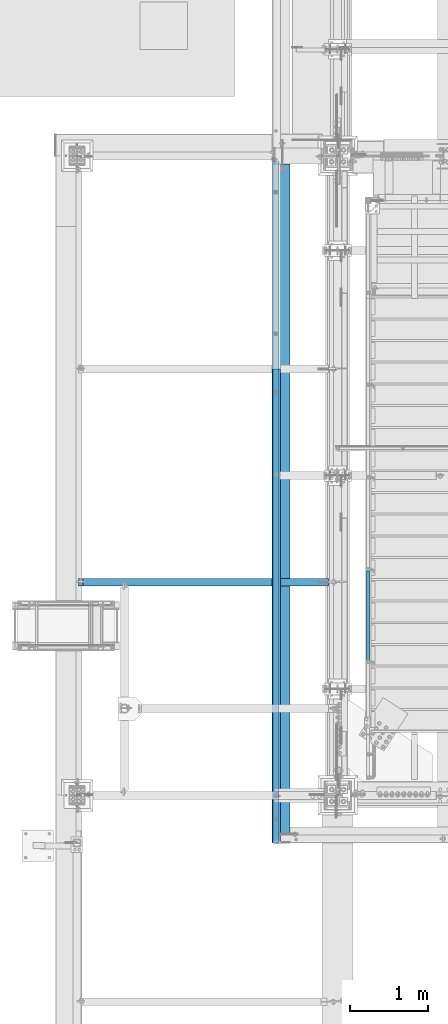
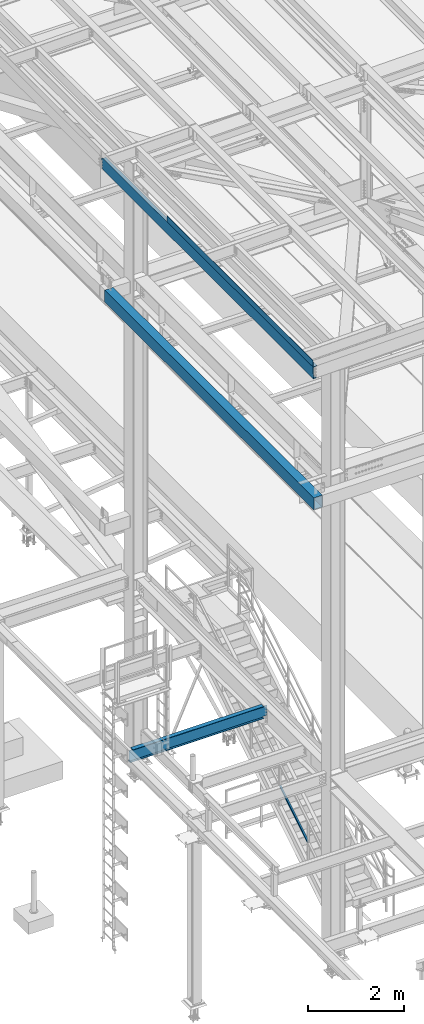
# One storey, part 1742 of 3843: 4 beams, 1 member, 4 elements without a shape of their own.
"""IFC2X3 building model written with IfcOpenShell, lengths in millimetres."""

import ifcopenshell
import ifcopenshell.guid

model = None  # the IFC model being written
_history = None  # IfcOwnerHistory: only IFC2X3 demands one
_inside = {}  # id of a spatial element -> (the spatial element, [elements in it])
_under = {}  # id of a project, library or spatial element -> (it, [spatial elements below it])
_declared = {}  # id of a project -> (the project, [libraries it declares])
_typed = {}  # id of a type object -> (the type object, [elements of that type])
_made_of = {}  # id of a material, layer set ... -> (it, [elements and type objects made of it])


def new_model(schema):
    """Start an empty IFC model of exactly this schema.

    Asked for "IFC4X3", IfcOpenShell would pick the latest addendum, in which some entities
    have other attributes; the version numbers below select the first issue.
    IFC2X3 requires an IfcOwnerHistory on every rooted entity: one is made here for all.
    """
    global model, _history
    if schema == "IFC4X3":
        model = ifcopenshell.file(schema_version=(4, 3, 0, 0))
    else:
        model = ifcopenshell.file(schema=schema)
    _inside.clear()
    _under.clear()
    _declared.clear()
    _typed.clear()
    _made_of.clear()
    _history = None
    if model.schema == "IFC2X3":
        org = make("IfcOrganization", Name="unknown")
        user = make(
            "IfcPersonAndOrganization",
            ThePerson=make("IfcPerson", FamilyName="unknown"),
            TheOrganization=org,
        )
        app = make(
            "IfcApplication",
            ApplicationDeveloper=org,
            Version="unknown",
            ApplicationFullName="unknown",
            ApplicationIdentifier="unknown",
        )
        _history = make(
            "IfcOwnerHistory",
            OwningUser=user,
            OwningApplication=app,
            ChangeAction="ADDED",
            CreationDate=0,
        )
    return model


def make(cls, **values):
    """One entity of the class cls with the attributes given. An attribute that is None is left unset."""
    return model.create_entity(
        cls, **{name: value for name, value in values.items() if value is not None}
    )


def rooted(cls, **values):
    """An entity with a GlobalId (a new one), such as an element, a storey or a relation."""
    return make(cls, GlobalId=ifcopenshell.guid.new(), OwnerHistory=_history, **values)


def si_unit(unit_type, name, prefix=None):
    """IfcSIUnit, for example si_unit("LENGTHUNIT", "METRE", prefix="MILLI")."""
    return make("IfcSIUnit", UnitType=unit_type, Prefix=prefix, Name=name)


def assignment(units):
    """IfcUnitAssignment: the units of a project."""
    return None if units is None else make("IfcUnitAssignment", Units=units)


def point(xyz):
    """IfcCartesianPoint."""
    return None if xyz is None else make("IfcCartesianPoint", Coordinates=xyz)


def direction(xyz):
    """IfcDirection."""
    return None if xyz is None else make("IfcDirection", DirectionRatios=xyz)


def frame(location, z_axis=None, x_axis=None):
    """IfcAxis2Placement3D, a coordinate frame: its origin and axes. An axis left out is left unset."""
    return make(
        "IfcAxis2Placement3D",
        Location=point(location),
        Axis=direction(z_axis),
        RefDirection=direction(x_axis),
    )


def origin_with_axes():
    """The frame at (0, 0, 0) with the z axis (0, 0, 1) and the x axis (1, 0, 0) written out."""
    return frame((0.0, 0.0, 0.0), z_axis=(0.0, 0.0, 1.0), x_axis=(1.0, 0.0, 0.0))


def place(relative_to, where):
    """IfcLocalPlacement: puts the frame where relative to a parent placement (None: the world)."""
    return make(
        "IfcLocalPlacement", PlacementRelTo=relative_to, RelativePlacement=where
    )


def context(
    kind, dimensions, precision=None, world=None, true_north=None, identifier=None
):
    """IfcGeometricRepresentationContext, for example the 3D "Model" context."""
    return make(
        "IfcGeometricRepresentationContext",
        ContextIdentifier=identifier,
        ContextType=kind,
        CoordinateSpaceDimension=dimensions,
        Precision=precision,
        WorldCoordinateSystem=world,
        TrueNorth=true_north,
    )


def subcontext(parent, identifier, kind, view, scale=None):
    """IfcGeometricRepresentationSubContext, for example "Body" below "Model"."""
    return make(
        "IfcGeometricRepresentationSubContext",
        ContextIdentifier=identifier,
        ContextType=kind,
        ParentContext=parent,
        TargetScale=scale,
        TargetView=view,
    )


def project(units=None, contexts=None):
    """IfcProject with its units and contexts."""
    return rooted(
        "IfcProject",
        Name="project",
        RepresentationContexts=contexts,
        UnitsInContext=assignment(units),
    )


def spatial(cls, under=None, at=None, **own):
    """A site, building, storey or space (cls), placed at a placement, below another one or the project."""
    s = rooted(cls, ObjectPlacement=at, **own)
    if under is not None:
        _under.setdefault(under.id(), (under, []))[1].append(s)
    return s


def faces_of(points, faces, orient=None, outer=None):
    """IfcFace entities. A face is a list of loops; a loop is a list of indices into points, from 0.

    orient and outer hold one flag for each loop. By default every Orientation is true, the
    first loop of a face is its IfcFaceOuterBound and the others are IfcFaceBound.
    """
    made = []
    for i, loops in enumerate(faces):
        bounds = []
        for j, loop in enumerate(loops):
            is_outer = j == 0 if outer is None else outer[i][j]
            bounds.append(
                make(
                    "IfcFaceOuterBound" if is_outer else "IfcFaceBound",
                    Bound=make("IfcPolyLoop", Polygon=[points[k] for k in loop]),
                    Orientation=True if orient is None else orient[i][j],
                )
            )
        made.append(make("IfcFace", Bounds=bounds))
    return made


def faceted_brep(points, faces, orient=None, outer=None, voids=None):
    """IfcFacetedBrep: a solid bounded by flat faces; with voids (closed shells), ...WithVoids."""
    shared = [point(p) for p in points]
    hull = make("IfcClosedShell", CfsFaces=faces_of(shared, faces, orient, outer))
    if voids is None:
        return make("IfcFacetedBrep", Outer=hull)
    return make(
        "IfcFacetedBrepWithVoids",
        Outer=hull,
        Voids=[
            make(cls, CfsFaces=faces_of(shared, fs, o, b)) for cls, fs, o, b in voids
        ],
    )


def shape(context_of_items, identifier, shape_type, items):
    """IfcShapeRepresentation: the items that make up one representation, for example the "Body"."""
    return make(
        "IfcShapeRepresentation",
        ContextOfItems=context_of_items,
        RepresentationIdentifier=identifier,
        RepresentationType=shape_type,
        Items=items,
    )


def material(Name=None, Category=None):
    """IfcMaterial."""
    return make("IfcMaterial", Name=Name, Category=Category)


def made_of(thing, what):
    """Note that an element or type object is made of a material, layer set ...; save() writes the relation."""
    if what is not None:
        _made_of.setdefault(what.id(), (what, []))[1].append(thing)
    return thing


def type_object(cls, material=None, **own):
    """A type object (cls), such as IfcWallType, which elements share."""
    return made_of(rooted(cls, **own), material)


def element(
    cls,
    number,
    at=None,
    inside=None,
    cuts=None,
    type_object=None,
    material=None,
    context=None,
    identifier="Body",
    shape_type=None,
    held_by="IfcProductDefinitionShape",
    body=None,
    shapes=None,
    **own,
):
    """One element of the class cls, such as IfcWall. Its Tag is "e" and its number.

    at: its placement. inside: the storey or other place that contains it. cuts: it is an
    opening in that element (IfcRelVoidsElement). A single representation is given by context,
    identifier, shape_type and body (its items); several are given by shapes. held_by: the class
    of the entity that holds the representations. save() writes the other relations.
    """
    e = rooted(cls, Tag="e%d" % number, ObjectPlacement=at, **own)
    if body is not None:
        shapes = [shape(context, identifier, shape_type, body)]
    if shapes is not None:
        e.Representation = make(held_by, Representations=shapes)
    if inside is not None:
        _inside.setdefault(inside.id(), (inside, []))[1].append(e)
    if cuts is not None:
        rooted(
            "IfcRelVoidsElement", RelatingBuildingElement=cuts, RelatedOpeningElement=e
        )
    if type_object is not None:
        _typed.setdefault(type_object.id(), (type_object, []))[1].append(e)
    return made_of(e, material)


def aggregate(whole, parts):
    """IfcRelAggregates: a whole, such as a stair, and the parts it consists of."""
    return rooted("IfcRelAggregates", RelatingObject=whole, RelatedObjects=parts)


def save(model, path):
    """Write the relations noted so far, then the file.

    IfcRelAggregates (storeys below a building ...), IfcRelContainedInSpatialStructure (elements
    in a storey), IfcRelDefinesByType, IfcRelAssociatesMaterial and IfcRelDeclares: one each for
    every whole, place, type object, material and project.
    """
    for whole, parts in _under.values():
        aggregate(whole, parts)
    for where, things in _inside.values():
        rooted(
            "IfcRelContainedInSpatialStructure",
            RelatedElements=things,
            RelatingStructure=where,
        )
    for kind, things in _typed.values():
        rooted("IfcRelDefinesByType", RelatedObjects=things, RelatingType=kind)
    for what, things in _made_of.values():
        rooted("IfcRelAssociatesMaterial", RelatedObjects=things, RelatingMaterial=what)
    for by, libraries in _declared.values():
        rooted("IfcRelDeclares", RelatingContext=by, RelatedDefinitions=libraries)
    model.write(path)


model = new_model("IFC2X3")

# Units and contexts
model_context = context("Model", 3, precision=1e-05, world=origin_with_axes())
body_context = subcontext(model_context, "Body", "Model", "MODEL_VIEW")
ifc_project = project(units=[si_unit("LENGTHUNIT", "METRE", prefix="MILLI"), si_unit("AREAUNIT", "SQUARE_METRE"), si_unit("VOLUMEUNIT", "CUBIC_METRE"), si_unit("MASSUNIT", "GRAM", prefix="KILO"), si_unit("TIMEUNIT", "SECOND"), si_unit("PLANEANGLEUNIT", "RADIAN"), si_unit("SOLIDANGLEUNIT", "STERADIAN"), si_unit("THERMODYNAMICTEMPERATUREUNIT", "DEGREE_CELSIUS"), si_unit("LUMINOUSINTENSITYUNIT", "LUMEN")], contexts=[model_context])

# Site, building, storey
site_placement = place(None, origin_with_axes())
site = spatial("IfcSite", under=ifc_project, at=site_placement, CompositionType="ELEMENT")
building_placement = place(site_placement, origin_with_axes())
building = spatial("IfcBuilding", under=site, at=building_placement, Name="Undefined", CompositionType="ELEMENT")
storey_placement = place(building_placement, origin_with_axes())
storey = spatial("IfcBuildingStorey", under=building, at=storey_placement, Name="Undefined", CompositionType="ELEMENT", Elevation=0.0)

# Assembly, member
assembly_1_placement = place(storey_placement, origin_with_axes())
assembly_1 = element("IfcElementAssembly", 1, at=assembly_1_placement, inside=storey, Name="RAIL", AssemblyPlace="NOTDEFINED", PredefinedType="RIGID_FRAME")
ifc_material_1 = material()
member_type = type_object("IfcMemberType", Name="HSS1-1/2X1-1/2X1/4", PredefinedType="NOTDEFINED")
member_placement = place(assembly_1_placement, frame((36969.6999999476, 27336.75, 31753.6285717874), z_axis=(0.0, -0.529007926750979, 0.848616882600523), x_axis=(0.0, 0.848616882600524, 0.529007926750978)))
member = element("IfcMember", 2, at=member_placement, type_object=member_type, material=ifc_material_1, Name="RAIL", ObjectType="HSS1-1/2X1-1/2X1/4", context=body_context, shape_type="Brep", body=[
    faceted_brep([(1388.70393079125, -19.0500003643538, 19.0499992334262), (1364.95328239725, -19.0499992350015, -19.0499992364712), (1364.95328239725, 19.0499992350015, -19.0499992364712), (1388.70393079125, 19.0499992350015, 19.0499992334262), (1384.74548929282, -12.6999993299978, 12.699999328448), (1384.74548929282, 12.6999993299978, 12.699999328448), (1368.91172389637, 12.6999993299978, -12.6999993314894), (1368.91172389637, -12.6999993299978, -12.6999993314894), (10.5729683018217, 19.0499992350015, -19.0499992349742), (34.3236166958304, 19.0499992350015, 19.0499992349305), (34.3236166958304, -19.0500000222455, 19.0499992349305), (10.5729683018217, -19.0499992350015, -19.0499992349742), (30.3651751973375, -12.6999993299978, 12.6999993299451), (14.5314098008821, -12.6999993299978, -12.6999993299924), (14.5314098008821, 12.6999993299978, -12.6999993299924), (30.3651751973375, 12.6999993299978, 12.6999993299451)], [[[0, 1, 2, 3], [4, 5, 6, 7]], [[8, 9, 3, 2]], [[9, 10, 0, 3]], [[10, 11, 1, 0]], [[11, 8, 2, 1]], [[10, 9, 8, 11], [12, 13, 14, 15]], [[13, 12, 4, 7]], [[14, 13, 7, 6]], [[15, 14, 6, 5]], [[12, 15, 5, 4]]]),
])
aggregate(assembly_1, [member])

# Assembly, beams
assembly_2_placement = place(storey_placement, origin_with_axes())
assembly_2 = element("IfcElementAssembly", 3, at=assembly_2_placement, inside=storey, Name="BEAM", AssemblyPlace="NOTDEFINED", PredefinedType="RIGID_FRAME")
ifc_material_2 = material(Name="STEEL/A572-50")
beam_type_1 = type_object("IfcBeamType", Name="C12X20.7", PredefinedType="NOTDEFINED")
beam_1_placement = place(assembly_2_placement, frame((35779.1150555175, 25006.3, 45560.3009647394), z_axis=(-0.0211520980073474, 0.0, 0.999776269347241), x_axis=(0.0, 1.0, 0.0)))
beam_1 = element("IfcBeam", 4, at=beam_1_placement, type_object=beam_type_1, material=ifc_material_2, Name="BEAM", ObjectType="C12X20.7", context=body_context, shape_type="Brep", body=[
    faceted_brep([(8772.52499999999, -38.1000000000931, -146.047459999718), (8772.52499999999, -38.1000000001004, -152.39999999971), (8772.52499999999, 38.0999999997803, -152.399999999783), (8772.52499999999, 38.0999999997875, -139.699999807606), (8772.52499999999, 1.15353759611025e-06, -139.699999807563), (8773.49172992257, 38.0999999997948, -134.839920289574), (8773.49172992257, 30.1624999998166, -134.6749274998), (8776.24474382306, 38.0999999997948, -130.71974382145), (8776.24474382306, 30.1624999998166, -130.719743821435), (8780.36492029121, 38.0999999998021, -127.966729920983), (8780.36492029121, 30.1624999998166, -127.966729920976), (8785.22499980926, 38.0999999998094, -126.999999998392), (8785.22499980926, 30.1624999998166, -126.999999998392), (8823.32499999999, 30.1624999998166, -126.999999998392), (8823.32499999999, 38.0999999998094, -126.999999998392), (0.0, -38.0999999999985, 152.400000000001), (0.0, -38.0999999999985, 146.047460000002), (8772.52499999999, -38.0999999998021, 146.047459999805), (8772.52499999999, -38.0999999997948, 152.399999999798), (0.0, 38.0999999999985, 152.400000000001), (8772.52499999999, 38.1000000000786, 152.399999999725), (0.0, -38.0999999999985, -152.400000000001), (0.0, -38.0999999999985, -146.047460000002), (0.0, 30.1624999999985, -134.6749275), (0.0, 30.1624999999985, 134.6749275), (0.0, 38.0999999999985, -152.400000000001), (8773.49172992257, 30.1625000000786, 134.674927499764), (8772.52499999999, 1.14230351755396e-06, 139.699999809491), (8772.52499999999, 38.1000000000713, 139.699999809454), (8773.49172992257, 38.100000000064, 134.839920291437), (8776.24474382306, 30.1625000000786, 130.719743823305), (8776.24474382306, 38.100000000064, 130.719743823305), (8780.36492029121, 30.1625000000713, 127.966729922853), (8780.36492029121, 38.100000000064, 127.966729922839), (8785.22499980926, 30.1625000000713, 127.000000000269), (8785.22499980926, 38.1000000000568, 127.000000000255), (8823.32499999999, 30.1625000000713, 127.000000000269), (8823.32499999999, 38.1000000000568, 127.000000000255), (8823.32499999999, 30.1625000000568, 114.299999981558), (8823.32499999999, 30.1624999998312, -116.300000012481)], [[[0, 1, 2, 3, 4]], [[4, 3, 5, 6]], [[6, 5, 7, 8]], [[8, 7, 9, 10]], [[10, 9, 11, 12]], [[13, 12, 11, 14]], [[15, 16, 17, 18]], [[19, 15, 18, 20]], [[21, 22, 23, 24, 16, 15, 19, 25]], [[17, 16, 24, 26, 27]], [[18, 17, 27, 28, 20]], [[26, 29, 28, 27]], [[30, 31, 29, 26]], [[32, 33, 31, 30]], [[34, 35, 33, 32]], [[36, 37, 35, 34]], [[37, 36, 38, 39, 13, 14]], [[9, 7, 5, 3, 2, 25, 19, 20, 28, 29, 31, 33, 35, 37, 14, 11]], [[21, 25, 2, 1]], [[22, 21, 1, 0]], [[23, 22, 0, 4, 6]], [[39, 38, 36, 34, 32, 30, 26, 24, 23, 6, 8, 10, 12, 13]]]),
])
ifc_material_3 = material(Name="STEEL/A36")
beam_type_2 = type_object("IfcBeamType", PredefinedType="NOTDEFINED")
beam_2_placement = place(assembly_2_placement, frame((35839.3101109711, 28054.3000000001, 45717.1843160648), z_axis=(0.0, -1.0, 0.0), x_axis=(-0.999776270257024, 0.0, -0.0211520550054595)))
beam_2 = element("IfcBeam", 5, at=beam_2_placement, type_object=beam_type_2, material=ifc_material_3, Name="BENT_PLATE", context=body_context, shape_type="Brep", body=[
    faceted_brep([(-3.50355549016967e-07, -3.17499999742722, -3048.00000001723), (3.50421032635495e-07, -3.17500000260043, 3048.00000001724), (3.5035191103816e-07, 3.17499999739084, 3048.00000001724), (-3.50424670614302e-07, 3.17500000256405, -3048.00000001723), (101.599999864371, 3.17499999856227, 3048.00000000522), (101.599998739839, 3.17500000373548, -3048.00000002925), (95.249998765099, -3.17499999632128, -3048.00000002851), (95.2499998896274, -3.17500000149448, 3048.00000000597), (101.600000309205, -161.925000875126, 3047.9999999938), (101.599999608374, -161.925000446165, -3048.00000004067), (95.2500003092064, -161.925000900388, 3047.99999999456), (95.2499996083752, -161.925000471427, -3048.00000003992)], [[[0, 1, 2, 3]], [[3, 2, 4, 5]], [[1, 0, 6, 7]], [[5, 4, 8, 9]], [[4, 2, 1, 7, 10, 8]], [[7, 6, 11, 10]], [[6, 0, 3, 5, 9, 11]], [[10, 11, 9, 8]]]),
])
aggregate(assembly_2, [beam_2, beam_1])

# Assembly, beam
assembly_3_placement = place(storey_placement, origin_with_axes())
assembly_3 = element("IfcElementAssembly", 6, at=assembly_3_placement, inside=storey, Name="GIRT", AssemblyPlace="NOTDEFINED", PredefinedType="RIGID_FRAME")
ifc_material_4 = material()
beam_type_3 = type_object("IfcBeamType", Name="HSS12X8X3/8", PredefinedType="NOTDEFINED")
beam_3_placement = place(assembly_3_placement, frame((35861.6250000001, 25006.3, 42214.8000000001), z_axis=(0.0, 0.0, 1.0), x_axis=(0.0, 1.0, 0.0)))
beam_3 = element("IfcBeam", 7, at=beam_3_placement, type_object=beam_type_3, material=ifc_material_4, Name="GIRT", ObjectType="HSS12X8X3/8", context=body_context, shape_type="Brep", body=[
    faceted_brep([(6.35000000002037, -101.600000000006, -152.400000000001), (6.35000000002037, 101.600000000006, -152.400000000001), (8736.01249999999, 101.599999999999, -152.400000000001), (8736.01249999999, -101.599999999999, -152.400000000001), (6.35000000002037, -101.600000000006, 152.400000000001), (8736.01249999999, -101.599999999999, 152.400000000001), (6.35000000002037, 101.600000000006, 152.400000000001), (8736.01249999999, 101.599999999999, 152.400000000001), (6.35000000002037, 92.0749999999971, 142.875), (6.35000000002037, -92.0749999999971, 142.875), (6.35000000002037, -92.0749999999971, -142.875), (6.35000000002037, 92.0749999999971, -142.875), (8736.01249999999, -92.0749999999971, 142.875), (8736.01249999999, -92.0749999999971, -142.875), (8736.01249999999, 92.0749999999971, -142.875), (8736.01249999999, 92.0749999999971, 142.875)], [[[0, 1, 2, 3]], [[4, 0, 3, 5]], [[6, 4, 5, 7]], [[1, 6, 7, 2]], [[0, 4, 6, 1], [8, 9, 10, 11]], [[10, 9, 12, 13]], [[11, 10, 13, 14]], [[8, 11, 14, 15]], [[9, 8, 15, 12]], [[2, 7, 5, 3], [14, 13, 12, 15]]]),
])
aggregate(assembly_3, [beam_3])

assembly_4_placement = place(storey_placement, origin_with_axes())
assembly_4 = element("IfcElementAssembly", 8, at=assembly_4_placement, inside=storey, Name="BEAM", AssemblyPlace="NOTDEFINED", PredefinedType="RIGID_FRAME")
ifc_material_5 = material(Name="STEEL/A992")
beam_type_4 = type_object("IfcBeamType", Name="W12X19", PredefinedType="NOTDEFINED")
beam_4_placement = place(assembly_4_placement, frame((33223.2, 28359.1, 34656.7125), z_axis=(0.0, 0.0, 1.0), x_axis=(1.0, 0.0, 0.0)))
beam_4 = element("IfcBeam", 9, at=beam_4_placement, type_object=beam_type_4, material=ifc_material_5, Name="BEAM", ObjectType="W12X19", context=body_context, shape_type="Brep", body=[
    faceted_brep([(3233.73750000002, -3.17499999999927, -144.462500000001), (3233.73750000002, -50.7999999999993, -144.462500000001), (3233.73750000002, -50.7999999999993, -153.987500000003), (3233.73750000002, 50.7999999999993, -153.987500000003), (3233.73750000002, 50.7999999999993, -144.462500000001), (3233.73750000002, 3.17499999999927, -144.462500000001), (3233.73750000002, 3.17499999999927, -141.287499809274), (3233.73750000002, -3.17499999999927, -141.287499809274), (3234.70422992261, 3.17499999999927, -136.427420291227), (3234.70422992261, -3.17499999999927, -136.427420291227), (3237.45724382308, 3.17499999999927, -132.307243823074), (3237.45724382308, -3.17499999999927, -132.307243823074), (3241.57742029124, 3.17499999999927, -129.5542299226), (3241.57742029124, -3.17499999999927, -129.5542299226), (3246.43749980928, 3.17499999999927, -128.587500000009), (3246.43749980928, -3.17499999999927, -128.587500000009), (3335.33750000001, -3.17499999999927, -128.587500000009), (3335.33750000001, 3.17499999999927, -128.587500000009), (79.3749999999927, 3.17500000000291, 144.462500000001), (79.3749999999927, 50.8000000000029, 144.462500000001), (3233.73750000002, 50.7999999999993, 144.462500000001), (3233.73750000002, 3.17499999999927, 144.462500000001), (15.8750000000146, 3.17500000000291, 115.887500001612), (15.8750000000146, 3.17500000000291, -114.712499998386), (15.8749999999927, 3.17500000000291, -144.462500000001), (15.8749999999927, 50.8000000000029, -144.462500000001), (15.8749999999927, 50.8000000000029, -153.987500000003), (15.8749999999927, -50.8000000000029, -153.987500000003), (15.8749999999927, -50.8000000000029, -144.462500000001), (15.8749999999927, -3.17500000000291, -144.462500000001), (15.8750000000146, -3.17500000000291, 128.587500001042), (15.8750000000146, 3.17500000000291, 128.587500001042), (66.6750001907276, -3.17500000000291, 128.587500000001), (66.6750001907276, 3.17500000000291, 128.587500000001), (71.535079708774, -3.17500000000291, 129.554229922593), (71.535079708774, 3.17500000000291, 129.554229922593), (75.6552561769277, -3.17500000000291, 132.307243823067), (75.6552561769277, 3.17500000000291, 132.307243823067), (78.4082700774052, -3.17500000000291, 136.42742029122), (78.4082700774052, 3.17500000000291, 136.42742029122), (79.3749999999927, -3.17500000000291, 141.287499809267), (79.3749999999927, 3.17500000000291, 141.287499809267), (79.375, -50.7999999999993, 153.987500000003), (79.3749999999927, 50.8000000000029, 153.987500000003), (79.3749999999927, -3.17500000000291, 144.462500000001), (79.3749999999927, -50.8000000000029, 144.462500000001), (3233.73750000002, -3.17499999999927, 144.462500000001), (3233.73750000002, -50.7999999999993, 144.462500000001), (3233.73750000002, -50.7999999999993, 153.987500000003), (3233.73750000002, 50.7999999999993, 153.987500000003), (3233.73750000002, -3.17499999999927, 141.287499809259), (3233.73750000002, 3.17499999999927, 141.287499809259), (3234.70422992261, -3.17499999999927, 136.427420291213), (3234.70422992261, 3.17499999999927, 136.427420291213), (3237.45724382308, -3.17499999999927, 132.307243823059), (3237.45724382308, 3.17499999999927, 132.307243823059), (3241.57742029124, -3.17499999999927, 129.554229922585), (3241.57742029124, 3.17499999999927, 129.554229922585), (3246.43749980928, -3.17499999999927, 128.587499999994), (3246.43749980928, 3.17499999999927, 128.587499999994), (3335.33750000001, -3.17499999999927, 128.587499999994), (3335.33750000001, 3.17499999999927, 128.587499999994)], [[[0, 1, 2, 3, 4, 5, 6, 7]], [[7, 6, 8, 9]], [[9, 8, 10, 11]], [[11, 10, 12, 13]], [[13, 12, 14, 15]], [[16, 15, 14, 17]], [[18, 19, 20, 21]], [[22, 23, 24, 25, 26, 27, 28, 29, 30, 31]], [[32, 33, 31, 30]], [[34, 35, 33, 32]], [[36, 37, 35, 34]], [[38, 39, 37, 36]], [[40, 41, 39, 38]], [[42, 43, 19, 18, 41, 40, 44, 45]], [[45, 44, 46, 47]], [[42, 45, 47, 48]], [[43, 42, 48, 49]], [[19, 43, 49, 20]], [[48, 47, 46, 50, 51, 21, 20, 49]], [[52, 53, 51, 50]], [[54, 55, 53, 52]], [[56, 57, 55, 54]], [[58, 59, 57, 56]], [[60, 61, 59, 58]], [[61, 60, 16, 17]], [[12, 10, 8, 6, 5, 24, 23, 22, 31, 33, 35, 37, 39, 41, 18, 21, 51, 53, 55, 57, 59, 61, 17, 14]], [[25, 24, 5, 4]], [[26, 25, 4, 3]], [[27, 26, 3, 2]], [[28, 27, 2, 1]], [[29, 28, 1, 0]], [[60, 58, 56, 54, 52, 50, 46, 44, 40, 38, 36, 34, 32, 30, 29, 0, 7, 9, 11, 13, 15, 16]]]),
])
aggregate(assembly_4, [beam_4])

save(model, "model.ifc")
